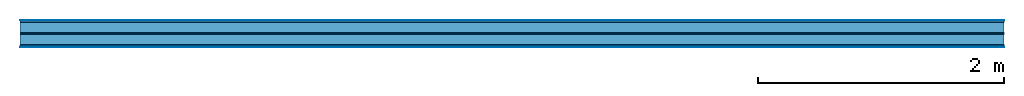
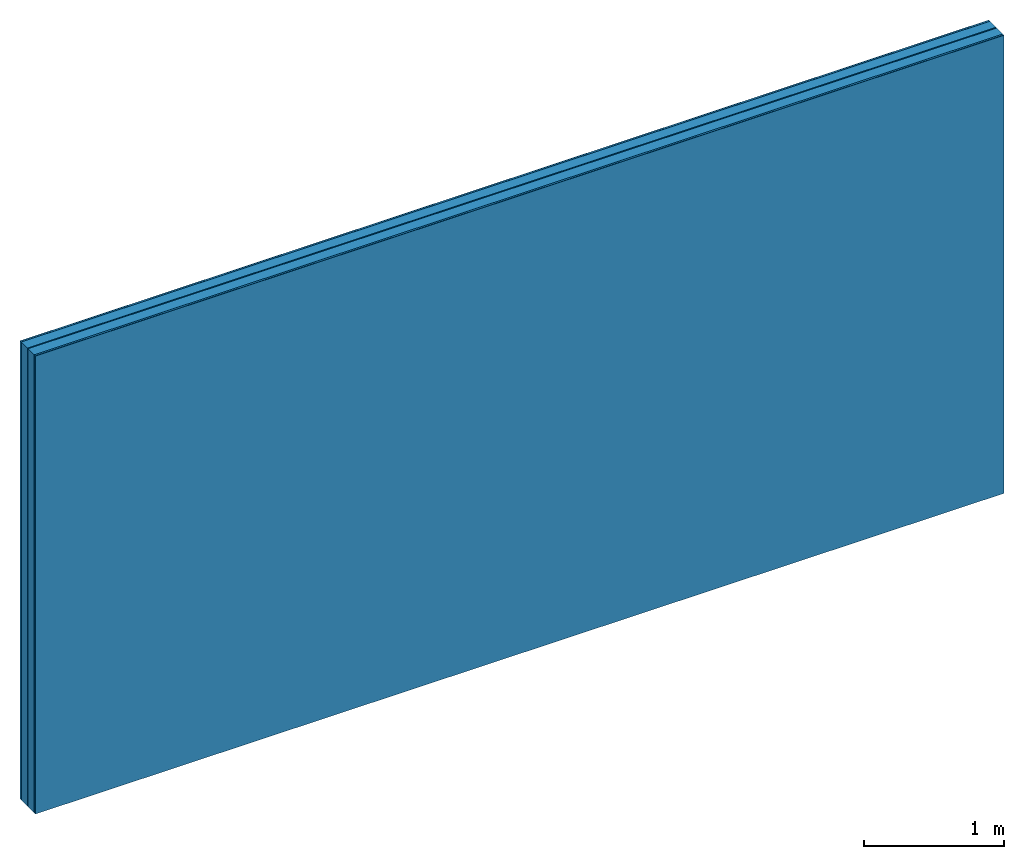
# One storey: 5 plates, 2 members, 1 element without a shape of its own.
"""IFC4 building model written with IfcOpenShell, lengths in metres."""

from ifc_helpers import new_model, si_unit, derived_unit, direction, frame, frame_2d, origin, origin_with_axes, place, context, project, spatial, rectangle, extrude, material, layer, layer_set, type_object, element, aggregate, save


model = new_model("IFC4")

# Units and contexts
plan_context = context("Plan", 3, precision=1e-05, world=origin(), true_north=direction((0.0, 1.0)))
model_context = context("Model", 3, precision=1e-05, world=origin(), true_north=direction((0.0, 1.0)))
ifc_project = project(units=[si_unit("LENGTHUNIT", "METRE"), derived_unit("SOUNDPRESSUREUNIT", [(si_unit("PRESSUREUNIT", "PASCAL", prefix="MICRO"), 0)]), si_unit("ENERGYUNIT", "JOULE", prefix="MEGA"), si_unit("MASSUNIT", "GRAM", prefix="KILO"), derived_unit("THERMALTRANSMITTANCEUNIT", [(si_unit("POWERUNIT", "WATT"), 1), (si_unit("AREAUNIT", "SQUARE_METRE"), -1), (si_unit("THERMODYNAMICTEMPERATUREUNIT", "KELVIN"), -1)]), derived_unit("AREADENSITYUNIT", [(si_unit("MASSUNIT", "GRAM", prefix="KILO"), 1), (si_unit("AREAUNIT", "SQUARE_METRE"), -1)]), derived_unit("USERDEFINED", [(si_unit("ENERGYUNIT", "JOULE", prefix="MEGA"), 1), (si_unit("AREAUNIT", "SQUARE_METRE"), -1)])], contexts=[plan_context, model_context])

# Site, building, storey
site = spatial("IfcSite", under=ifc_project)
building_placement = place(None, origin())
building = spatial("IfcBuilding", under=site, at=building_placement)
storey_placement = place(building_placement, origin())
storey = spatial("IfcBuildingStorey", under=building, at=storey_placement)

# Wall, members, plates
ifc_material_1 = material(Category="04.001")
ifc_layer_1 = layer(ifc_material_1, 0.003, Name="Surface")
ifc_material_2 = material(Name="DFH2IR Knauf Diamant hard- plasterboard", Category="03.007")
ifc_layer_2 = layer(ifc_material_2, 0.015, Name="room side 1st layer")
ifc_material_3 = material(Name="of the art")
ifc_layer_3 = layer(ifc_material_3, 0.0, Name="Bond")
ifc_layer_4 = layer(None, 0.087, Name="Support")
ifc_layer_5 = layer(ifc_material_3, 0.0, Name="Bond")
ifc_material_4 = material(Name="Air")
ifc_layer_6 = layer(ifc_material_4, 0.01, Name="Air gap")
ifc_layer_7 = layer(ifc_material_3, 0.0, Name="Bond")
ifc_layer_8 = layer(None, 0.087, Name="Support")
ifc_layer_9 = layer(ifc_material_3, 0.0, Name="Bond")
ifc_layer_10 = layer(ifc_material_2, 0.015, Name="room side 1st layer")
ifc_layer_11 = layer(ifc_material_1, 0.003, Name="Surface")
ifc_layer_set = layer_set([ifc_layer_1, ifc_layer_2, ifc_layer_3, ifc_layer_4, ifc_layer_5, ifc_layer_6, ifc_layer_7, ifc_layer_8, ifc_layer_9, ifc_layer_10, ifc_layer_11])
wall_type = type_object("IfcWallType", Name="B0263", PredefinedType="NOTDEFINED", material=ifc_layer_set)
wall_placement = place(None, frame((0.0, 0.0, 0.0), z_axis=(0.0, -1.0, 0.0), x_axis=(1.0, 0.0, 0.0)))
wall = element("IfcWall", 1, at=wall_placement, inside=storey, type_object=wall_type, material=ifc_layer_set, Name="Wall #1")
ifc_material_5 = material(Name="Solid timber panel")
member_1_placement = place(wall_placement, origin())
member_1 = element("IfcMember", 2, at=member_1_placement, material=ifc_material_5, Name="Support", context=plan_context, shape_type="SweptSolid", body=[
    extrude(rectangle(XDim=1.0, YDim=0.087, at=frame_2d((0.5, 0.0435), x_axis=(1.0, 0.0))), frame((0.0, 4.0, 0.018), z_axis=(0.0, -1.0, 0.0), x_axis=(1.0, 0.0, 0.0)), (0.0, 0.0, 1.0), 4.0),
    extrude(rectangle(XDim=1.0, YDim=0.087, at=frame_2d((0.5, 0.0435), x_axis=(1.0, 0.0))), frame((1.0, 4.0, 0.018), z_axis=(0.0, -1.0, 0.0), x_axis=(1.0, 0.0, 0.0)), (0.0, 0.0, 1.0), 4.0),
    extrude(rectangle(XDim=1.0, YDim=0.087, at=frame_2d((0.5, 0.0435), x_axis=(1.0, 0.0))), frame((2.0, 4.0, 0.018), z_axis=(0.0, -1.0, 0.0), x_axis=(1.0, 0.0, 0.0)), (0.0, 0.0, 1.0), 4.0),
    extrude(rectangle(XDim=1.0, YDim=0.087, at=frame_2d((0.5, 0.0435), x_axis=(1.0, 0.0))), frame((3.0, 4.0, 0.018), z_axis=(0.0, -1.0, 0.0), x_axis=(1.0, 0.0, 0.0)), (0.0, 0.0, 1.0), 4.0),
    extrude(rectangle(XDim=1.0, YDim=0.087, at=frame_2d((0.5, 0.0435), x_axis=(1.0, 0.0))), frame((4.0, 4.0, 0.018), z_axis=(0.0, -1.0, 0.0), x_axis=(1.0, 0.0, 0.0)), (0.0, 0.0, 1.0), 4.0),
    extrude(rectangle(XDim=1.0, YDim=0.087, at=frame_2d((0.5, 0.0435), x_axis=(1.0, 0.0))), frame((5.0, 4.0, 0.018), z_axis=(0.0, -1.0, 0.0), x_axis=(1.0, 0.0, 0.0)), (0.0, 0.0, 1.0), 4.0),
    extrude(rectangle(XDim=1.0, YDim=0.087, at=frame_2d((0.5, 0.0435), x_axis=(1.0, 0.0))), frame((6.0, 4.0, 0.018), z_axis=(0.0, -1.0, 0.0), x_axis=(1.0, 0.0, 0.0)), (0.0, 0.0, 1.0), 4.0),
    extrude(rectangle(XDim=1.0, YDim=0.087, at=frame_2d((0.5, 0.0435), x_axis=(1.0, 0.0))), frame((7.0, 4.0, 0.018), z_axis=(0.0, -1.0, 0.0), x_axis=(1.0, 0.0, 0.0)), (0.0, 0.0, 1.0), 4.0),
])
member_2_placement = place(wall_placement, origin())
member_2 = element("IfcMember", 3, at=member_2_placement, material=ifc_material_5, Name="Support", context=plan_context, shape_type="SweptSolid", body=[
    extrude(rectangle(XDim=1.0, YDim=0.087, at=frame_2d((0.5, 0.0435), x_axis=(1.0, 0.0))), frame((0.0, 4.0, 0.115), z_axis=(0.0, -1.0, 0.0), x_axis=(1.0, 0.0, 0.0)), (0.0, 0.0, 1.0), 4.0),
    extrude(rectangle(XDim=1.0, YDim=0.087, at=frame_2d((0.5, 0.0435), x_axis=(1.0, 0.0))), frame((1.0, 4.0, 0.115), z_axis=(0.0, -1.0, 0.0), x_axis=(1.0, 0.0, 0.0)), (0.0, 0.0, 1.0), 4.0),
    extrude(rectangle(XDim=1.0, YDim=0.087, at=frame_2d((0.5, 0.0435), x_axis=(1.0, 0.0))), frame((2.0, 4.0, 0.115), z_axis=(0.0, -1.0, 0.0), x_axis=(1.0, 0.0, 0.0)), (0.0, 0.0, 1.0), 4.0),
    extrude(rectangle(XDim=1.0, YDim=0.087, at=frame_2d((0.5, 0.0435), x_axis=(1.0, 0.0))), frame((3.0, 4.0, 0.115), z_axis=(0.0, -1.0, 0.0), x_axis=(1.0, 0.0, 0.0)), (0.0, 0.0, 1.0), 4.0),
    extrude(rectangle(XDim=1.0, YDim=0.087, at=frame_2d((0.5, 0.0435), x_axis=(1.0, 0.0))), frame((4.0, 4.0, 0.115), z_axis=(0.0, -1.0, 0.0), x_axis=(1.0, 0.0, 0.0)), (0.0, 0.0, 1.0), 4.0),
    extrude(rectangle(XDim=1.0, YDim=0.087, at=frame_2d((0.5, 0.0435), x_axis=(1.0, 0.0))), frame((5.0, 4.0, 0.115), z_axis=(0.0, -1.0, 0.0), x_axis=(1.0, 0.0, 0.0)), (0.0, 0.0, 1.0), 4.0),
    extrude(rectangle(XDim=1.0, YDim=0.087, at=frame_2d((0.5, 0.0435), x_axis=(1.0, 0.0))), frame((6.0, 4.0, 0.115), z_axis=(0.0, -1.0, 0.0), x_axis=(1.0, 0.0, 0.0)), (0.0, 0.0, 1.0), 4.0),
    extrude(rectangle(XDim=1.0, YDim=0.087, at=frame_2d((0.5, 0.0435), x_axis=(1.0, 0.0))), frame((7.0, 4.0, 0.115), z_axis=(0.0, -1.0, 0.0), x_axis=(1.0, 0.0, 0.0)), (0.0, 0.0, 1.0), 4.0),
])
plate_1_placement = place(wall_placement, origin())
plate_1 = element("IfcPlate", 4, at=plate_1_placement, material=ifc_material_1, Name="Surface", context=plan_context, shape_type="SweptSolid", body=[
    extrude(rectangle(XDim=8.0, YDim=4.0, at=frame_2d((4.0, 2.0), x_axis=(1.0, 0.0))), origin_with_axes(), (0.0, 0.0, 1.0), 0.003),
])
plate_2_placement = place(wall_placement, origin())
plate_2 = element("IfcPlate", 5, at=plate_2_placement, material=ifc_material_2, Name="room side 1st layer", context=plan_context, shape_type="SweptSolid", body=[
    extrude(rectangle(XDim=8.0, YDim=4.0, at=frame_2d((4.0, 2.0), x_axis=(1.0, 0.0))), frame((0.0, 0.0, 0.003), z_axis=(0.0, 0.0, 1.0), x_axis=(1.0, 0.0, 0.0)), (0.0, 0.0, 1.0), 0.015),
])
plate_3_placement = place(wall_placement, origin())
plate_3 = element("IfcPlate", 6, at=plate_3_placement, material=ifc_material_4, Name="Air gap", context=plan_context, shape_type="SweptSolid", body=[
    extrude(rectangle(XDim=8.0, YDim=4.0, at=frame_2d((4.0, 2.0), x_axis=(1.0, 0.0))), frame((0.0, 0.0, 0.105), z_axis=(0.0, 0.0, 1.0), x_axis=(1.0, 0.0, 0.0)), (0.0, 0.0, 1.0), 0.01),
])
plate_4_placement = place(wall_placement, origin())
plate_4 = element("IfcPlate", 7, at=plate_4_placement, material=ifc_material_2, Name="room side 1st layer", context=plan_context, shape_type="SweptSolid", body=[
    extrude(rectangle(XDim=8.0, YDim=4.0, at=frame_2d((4.0, 2.0), x_axis=(1.0, 0.0))), frame((0.0, 0.0, 0.202), z_axis=(0.0, 0.0, 1.0), x_axis=(1.0, 0.0, 0.0)), (0.0, 0.0, 1.0), 0.015),
])
plate_5_placement = place(wall_placement, origin())
plate_5 = element("IfcPlate", 8, at=plate_5_placement, material=ifc_material_1, Name="Surface", context=plan_context, shape_type="SweptSolid", body=[
    extrude(rectangle(XDim=8.0, YDim=4.0, at=frame_2d((4.0, 2.0), x_axis=(1.0, 0.0))), frame((0.0, 0.0, 0.217), z_axis=(0.0, 0.0, 1.0), x_axis=(1.0, 0.0, 0.0)), (0.0, 0.0, 1.0), 0.003),
])
aggregate(wall, [plate_1, plate_2, member_1, plate_3, member_2, plate_4, plate_5])

save(model, "model.ifc")
